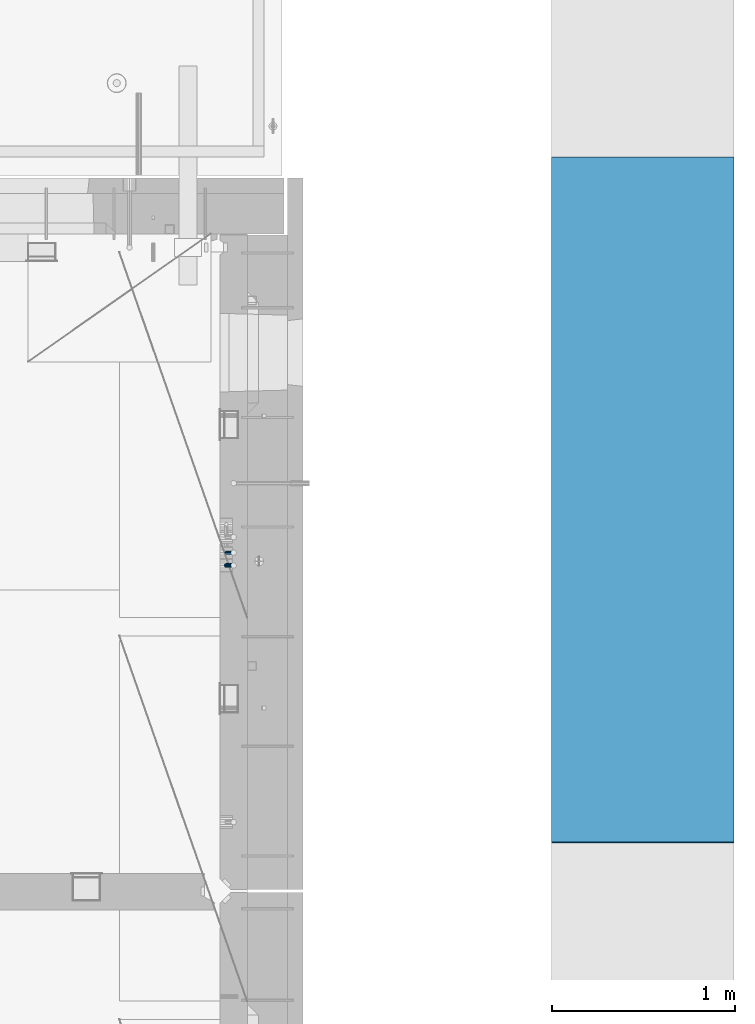
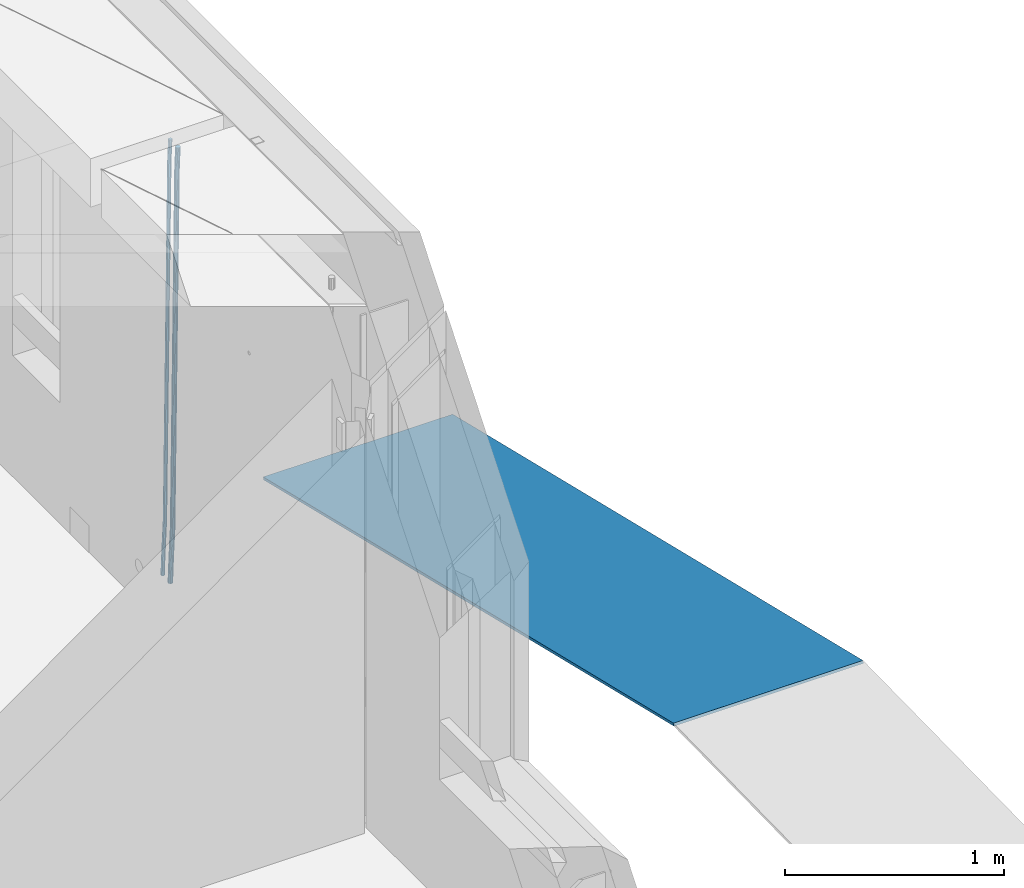
# One storey, part 116 of 325: 3 beams, 2 elements without a shape of their own.
"""IFC2X3 building model written with IfcOpenShell, lengths in millimetres."""

from ifc_helpers import new_model, si_unit, frame, origin_with_axes, place, context, subcontext, project, spatial, faceted_brep, material, type_object, element, aggregate, save


model = new_model("IFC2X3")

# Units and contexts
model_context = context("Model", 3, precision=1e-05, world=origin_with_axes())
body_context = subcontext(model_context, "Body", "Model", "MODEL_VIEW")
ifc_project = project(units=[si_unit("LENGTHUNIT", "METRE", prefix="MILLI"), si_unit("AREAUNIT", "SQUARE_METRE"), si_unit("VOLUMEUNIT", "CUBIC_METRE"), si_unit("MASSUNIT", "GRAM", prefix="KILO"), si_unit("TIMEUNIT", "SECOND"), si_unit("PLANEANGLEUNIT", "RADIAN"), si_unit("SOLIDANGLEUNIT", "STERADIAN"), si_unit("THERMODYNAMICTEMPERATUREUNIT", "DEGREE_CELSIUS"), si_unit("LUMINOUSINTENSITYUNIT", "LUMEN")], contexts=[model_context])

# Site, building, storey
site_placement = place(None, origin_with_axes())
site = spatial("IfcSite", under=ifc_project, at=site_placement, CompositionType="ELEMENT")
building_placement = place(site_placement, origin_with_axes())
building = spatial("IfcBuilding", under=site, at=building_placement, CompositionType="ELEMENT")
storey_placement = place(building_placement, origin_with_axes())
storey = spatial("IfcBuildingStorey", under=building, at=storey_placement, Name="1", CompositionType="ELEMENT", Elevation=0.0)

# Assembly, beams
assembly_1_placement = place(storey_placement, origin_with_axes())
assembly_1 = element("IfcElementAssembly", 1, at=assembly_1_placement, inside=storey, AssemblyPlace="NOTDEFINED", PredefinedType="REINFORCEMENT_UNIT")
ifc_material_1 = material()
beam_type_1 = type_object("IfcBeamType", Name="D20", PredefinedType="NOTDEFINED")
beam_1_placement = place(assembly_1_placement, frame((34944.9999977209, 18835.0002441367, 81990.0), z_axis=(0.999642804629538, 0.000205762999925497, -0.0267249099901003), x_axis=(0.0267249109941254, -4.30000210532798e-08, 0.999642825779465)))
beam_1 = element("IfcBeam", 2, at=beam_1_placement, type_object=beam_type_1, material=ifc_material_1, Name="JM20", ObjectType="D20", context=body_context, shape_type="Brep", body=[
    faceted_brep([(0.0, -10.0, 0.0), (-4.19531716033816e-08, -7.07106781186667, -7.07106781187031), (60.4266690400545, -7.0710677960451, -7.07106780570757), (60.4266690441291, -9.99999998418934, 6.15546014159918e-09), (0.0, 0.0, -10.0), (60.426669036824, 1.58106558956206e-08, -9.99999999384454), (4.196772351861e-08, 7.07106781186303, -7.07106781186667), (60.4266690363438, 7.07106782768096, -7.07106780570757), (0.0, 10.0, 0.0), (60.4266690388904, 10.0000000158179, 6.15182216279209e-09), (4.196772351861e-08, 7.07106781185939, 7.07106781185939), (60.4266690429649, 7.07106782768096, 7.07106781802577), (0.0, 0.0, 10.0), (60.4266690461809, 1.58179318532348e-08, 10.0000000061555), (-4.19531716033816e-08, -7.07106781187031, 7.07106781185939), (60.4266690466611, -7.07106779605238, 7.07106781802213), (61.0378400410118, -7.07106779588503, -7.07106780564936), (60.991799419251, -9.99999998403655, 6.21366780251265e-09), (61.0569027789461, 1.5985278878361e-08, -9.99999999378269), (61.0378209396877, 7.07106782784831, -7.07106780564936), (60.9917724058905, 10.0000000159635, 6.21366780251265e-09), (60.9457317841297, 7.07106782781193, 7.0710678180767), (60.9266690461809, 1.59488990902901e-08, 10.0000000062028), (60.9457508854539, -7.07106779591413, 7.0710678180767), (61.6489592143771, -7.07106614513759, -7.06310863441468), (61.5568818710308, -9.9999984576425, 0.00735959856683621), (61.6870830769039, 1.71821739058942e-06, -9.99179257185824), (61.6489210170112, 7.07106947854481, -7.06310888312146), (61.556827851804, 10.0000015422847, 0.00735924683976918), (61.4647505084577, 7.07106922979438, 7.07782747982128), (61.4266266459163, 1.36643211590126e-06, 10.0065114172685), (61.464788705809, -7.07106639389531, 7.07782772852806), (176.543135720174, -7.07075579406956, -5.56673531796696), (176.451058376813, -9.99968810657447, 1.50373291501455), (176.581259582701, 0.000312069292704109, -8.49541925541052), (176.543097522794, 7.07137982961285, -5.56673556667374), (176.451004357587, 10.00031189336, 1.50373256329476), (176.35892701424, 7.07137958085514, 8.57420079627263), (176.320803151699, 0.000311717507429421, 11.5028847337162), (176.358965211621, -7.07075604281999, 8.57420104497578), (177.098753836006, -7.07075429323595, -5.55949898843028), (176.98362511232, -9.99968666800123, 1.510669025065), (177.146421932586, 0.000313595905026887, -8.48805862247536), (177.098706077581, 7.07138133041735, -5.55949936166144), (176.983557571715, 10.0003133318824, 1.51066849724157), (176.868428848029, 7.07138095712435, 8.58083651073321), (176.820760751449, 0.000313067976094317, 11.5093961447819), (176.868476606425, -7.07075466652896, 8.58083688396073), (177.654312950661, -7.07075204110879, -5.54863964998367), (177.516135294456, -9.99968450931192, 1.52107783331303), (177.711524267797, 0.000315886711177882, -8.47701274570863), (177.654255632195, 7.07138358250813, -5.54864021007961), (177.516054233929, 10.0003154905207, 1.5210770412159), (177.377876577739, 7.0713830223176, 8.59079452451624), (177.320665260588, 0.000315094497636892, 11.5191676202448), (177.377933896176, -7.07075260129932, 8.59079508461218), (299.436796249574, -7.07025836271714, -3.1681962331204), (299.298618593355, -9.99919083092027, 3.90152125031091), (299.494007566798, 0.000809565110102994, -6.09656932889993), (299.436738931283, 7.07187726089978, -3.16819679320906), (299.298537533061, 10.0008091689197, 3.90152045822106), (299.160359876842, 7.07187670072017, 10.9712379416487), (299.103148559603, 0.000808772889286047, 13.8996110374392), (299.160417195119, -7.07025892290039, 10.9712385017483), (299.98743051647, -7.07025613056248, -3.15743315966392), (299.971788958996, -9.99918809853989, 3.91467979818117), (299.993912075952, 0.000811591617093654, -6.08679785393178), (299.987423933868, 7.07187949325817, -3.1574327280432), (299.971753863239, 10.0008119014747, 3.91467990454839), (299.95611230444, 7.07187992653053, 10.9867922621015), (299.949630744944, 0.000812204350950196, 13.9161569563694), (299.956118887014, -7.07025569729012, 10.9867918304735), (300.538107039494, -7.07025785017686, -3.16575821840888), (300.644985195438, -9.99919020432935, 3.90450175465594), (300.493854948218, 0.000810030429420294, -6.09435592770024), (300.538151196495, 7.071877773491, -3.16575855385963), (300.645047642858, 10.0008097955724, 3.90450128024895), (300.751925798773, 7.07187744142357, 10.9747612533101), (300.796177890064, 0.000809560813650023, 13.9033589625978), (300.751881641787, -7.07025818224065, 10.9747615887682), (2293.36490490142, -7.07648090940347, -33.2930642912361), (2293.47178305736, -10.0054132635523, -26.2228043181785), (2293.32065281013, -0.00541302880083094, -36.2216620005347), (2293.36494905842, 7.06565471425711, -33.2930646266868), (2293.47184550477, 9.99458673634581, -26.2228047925819), (2293.57872366071, 7.06565438219332, -19.1525448195243), (2293.62297575199, -0.00541349841296324, -16.2239471102366), (2293.57867950371, -7.0764812414709, -19.1525444840736), (2294.0658245362, -7.07648309818615, -33.3036607065333), (2294.05312277409, -10.0054150789219, -26.2315929392535), (2294.10928714235, -0.00541549149056664, -36.2335844756526), (2294.15805078732, 7.06565223761572, -33.3050546393533), (2294.18355038921, 9.99458451388637, -26.2335642579346), (2294.17084862708, 7.06565253314329, -19.1614964906439), (2294.12738602093, -0.00541507354500936, -16.2315727215355), (2294.07862237596, -7.07648280265857, -19.1601025578348), (2294.76670261032, -7.08562269121467, -33.294332712383), (2294.63442802057, -10.0129954178956, -26.2238563411993), (2294.89787471293, -0.0156988342423574, -36.2230891548279), (2294.95110548967, 7.05531064255774, -33.2944998654275), (2294.89521307347, 9.98530428734011, -26.2240927312887), (2294.76293848372, 7.0579315606592, -19.1536163601049), (2294.63176638114, -0.0119922963167483, -16.2248599176673), (2294.57853560438, -7.08300177311321, -19.1534492070678), (2316.52657204497, -7.36937582653991, -33.0047303660212), (2316.39429745522, -10.2967485532172, -25.9342539948302), (2316.65774414754, -0.299451969567599, -35.9334868084661), (2316.7109749243, 6.7715575072325, -33.0048975190657), (2316.65508250811, 9.70155115201487, -25.9344903849269), (2316.52280791836, 6.7741784253376, -18.8640140137468), (2316.39163581574, -0.295745431634714, -15.9352575713092), (2316.33840503903, -7.36675490843481, -18.863846860706), (2317.16202064224, -7.37766220584308, -32.9962731735213), (2317.05438744847, -10.3053562613532, -25.9254688497131), (2317.23607125619, -0.306993473008333, -35.925789846493), (2317.23316144495, 6.76474808850253, -32.9979477328052), (2317.15499573652, 9.6950321815566, -25.9278370341635), (2317.04736254275, 6.7673381260538, -18.8570327103698), (2316.97331192881, -0.303330606784584, -15.9275160373909), (2316.97622174003, -7.37507216829545, -18.8553581510787), (2317.79752306276, -7.37578610372293, -32.9880110666527), (2317.71453320107, -10.3033876998124, -25.9168792378296), (2317.81444760226, -0.305295583297266, -35.918287695793), (2317.75539265381, 6.76628640723357, -32.9911928173897), (2317.65495180529, 9.69652304524061, -25.9213789128698), (2317.5719619436, 6.76892144914746, -18.8502470840467), (2317.55503740412, -0.301569071270933, -15.9199704549137), (2317.61409235255, -7.3731510618054, -18.847065333317), (2417.8183084176, -7.07752398473531, -31.6906369377139), (2417.73531855589, -10.0051255808248, -24.6195051088798), (2417.83523295709, -0.007033464313281, -34.6209135668432), (2417.77617800863, 7.06454852621755, -31.6938186884508), (2417.67573716014, 9.99478516423187, -24.6240047839383), (2417.59274729842, 7.06718356813872, -17.5528729551006), (2417.57582275895, -0.00330695228694822, -14.6225963259749), (2417.6348777074, -7.07488894281778, -17.5496912043673)], [[[0, 1, 2, 3]], [[1, 4, 5, 2]], [[4, 6, 7, 5]], [[6, 8, 9, 7]], [[8, 10, 11, 9]], [[10, 12, 13, 11]], [[12, 14, 15, 13]], [[14, 0, 3, 15]], [[14, 12, 10, 8, 6, 4, 1, 0]], [[3, 2, 16, 17]], [[2, 5, 18, 16]], [[5, 7, 19, 18]], [[7, 9, 20, 19]], [[9, 11, 21, 20]], [[11, 13, 22, 21]], [[13, 15, 23, 22]], [[15, 3, 17, 23]], [[17, 16, 24, 25]], [[16, 18, 26, 24]], [[18, 19, 27, 26]], [[19, 20, 28, 27]], [[20, 21, 29, 28]], [[21, 22, 30, 29]], [[22, 23, 31, 30]], [[23, 17, 25, 31]], [[25, 24, 32, 33]], [[24, 26, 34, 32]], [[26, 27, 35, 34]], [[27, 28, 36, 35]], [[28, 29, 37, 36]], [[29, 30, 38, 37]], [[30, 31, 39, 38]], [[31, 25, 33, 39]], [[33, 32, 40, 41]], [[32, 34, 42, 40]], [[34, 35, 43, 42]], [[35, 36, 44, 43]], [[36, 37, 45, 44]], [[37, 38, 46, 45]], [[38, 39, 47, 46]], [[39, 33, 41, 47]], [[41, 40, 48, 49]], [[40, 42, 50, 48]], [[42, 43, 51, 50]], [[43, 44, 52, 51]], [[44, 45, 53, 52]], [[45, 46, 54, 53]], [[46, 47, 55, 54]], [[47, 41, 49, 55]], [[49, 48, 56, 57]], [[48, 50, 58, 56]], [[50, 51, 59, 58]], [[51, 52, 60, 59]], [[52, 53, 61, 60]], [[53, 54, 62, 61]], [[54, 55, 63, 62]], [[55, 49, 57, 63]], [[57, 56, 64, 65]], [[56, 58, 66, 64]], [[58, 59, 67, 66]], [[59, 60, 68, 67]], [[60, 61, 69, 68]], [[61, 62, 70, 69]], [[62, 63, 71, 70]], [[63, 57, 65, 71]], [[65, 64, 72, 73]], [[64, 66, 74, 72]], [[66, 67, 75, 74]], [[67, 68, 76, 75]], [[68, 69, 77, 76]], [[69, 70, 78, 77]], [[70, 71, 79, 78]], [[71, 65, 73, 79]], [[73, 72, 80, 81]], [[72, 74, 82, 80]], [[74, 75, 83, 82]], [[75, 76, 84, 83]], [[76, 77, 85, 84]], [[77, 78, 86, 85]], [[78, 79, 87, 86]], [[79, 73, 81, 87]], [[81, 80, 88, 89]], [[80, 82, 90, 88]], [[82, 83, 91, 90]], [[83, 84, 92, 91]], [[84, 85, 93, 92]], [[85, 86, 94, 93]], [[86, 87, 95, 94]], [[87, 81, 89, 95]], [[89, 88, 96, 97]], [[88, 90, 98, 96]], [[90, 91, 99, 98]], [[91, 92, 100, 99]], [[92, 93, 101, 100]], [[93, 94, 102, 101]], [[94, 95, 103, 102]], [[95, 89, 97, 103]], [[97, 96, 104, 105]], [[96, 98, 106, 104]], [[98, 99, 107, 106]], [[99, 100, 108, 107]], [[100, 101, 109, 108]], [[101, 102, 110, 109]], [[102, 103, 111, 110]], [[103, 97, 105, 111]], [[105, 104, 112, 113]], [[104, 106, 114, 112]], [[106, 107, 115, 114]], [[107, 108, 116, 115]], [[108, 109, 117, 116]], [[109, 110, 118, 117]], [[110, 111, 119, 118]], [[111, 105, 113, 119]], [[113, 112, 120, 121]], [[112, 114, 122, 120]], [[114, 115, 123, 122]], [[115, 116, 124, 123]], [[116, 117, 125, 124]], [[117, 118, 126, 125]], [[118, 119, 127, 126]], [[119, 113, 121, 127]], [[121, 120, 128, 129]], [[120, 122, 130, 128]], [[122, 123, 131, 130]], [[123, 124, 132, 131]], [[124, 125, 133, 132]], [[125, 126, 134, 133]], [[126, 127, 135, 134]], [[127, 121, 129, 135]], [[130, 131, 132, 133, 134, 135, 129, 128]]]),
])
beam_type_2 = type_object("IfcBeamType", Name="D25", PredefinedType="NOTDEFINED")
beam_2_placement = place(assembly_1_placement, frame((34944.9999977209, 18765.0002441367, 81990.0), z_axis=(0.999642804629538, 0.000205762999925497, -0.0267249099901003), x_axis=(0.0267249109941254, -4.30000210532798e-08, 0.999642825779465)))
beam_2 = element("IfcBeam", 3, at=beam_2_placement, type_object=beam_type_2, material=ifc_material_1, Name="JM25", ObjectType="D25", context=body_context, shape_type="Brep", body=[
    faceted_brep([(-7.41420080885291e-08, -12.5, -3.63797880709171e-12), (-6.42030499875546e-08, -10.8253175473074, -6.25000000000364), (60.4103898235917, -10.8253175318459, -6.2499999938409), (60.4103898269532, -12.4999999845422, 6.16273609921336e-09), (-3.70782800018787e-08, -6.25000000000364, -10.8253175473074), (60.4103898202884, -6.24999998454587, -10.8253175411446), (-1.45519152283669e-11, -3.63797880709171e-12, -12.5), (60.4103898179019, 1.54577719513327e-08, -12.4999999938373), (3.70637280866504e-08, 6.25, -10.8253175473074), (60.410389817087, 6.25000001545777, -10.825317541141), (6.42030499875546e-08, 10.8253175473001, -6.25000000000364), (60.410389818062, 10.8253175627578, -6.24999999383726), (7.41420080885291e-08, 12.4999999999927, 0.0), (60.4103898205503, 12.5000000154541, 6.16273609921336e-09), (6.42176019027829e-08, 10.8253175473001, 6.24999999999636), (60.4103898238973, 10.8253175627651, 6.2500000061591), (3.70928319171071e-08, 6.24999999999636, 10.8253175473037), (60.4103898272151, 6.25000001546141, 10.8253175534664), (1.45519152283669e-11, -3.63797880709171e-12, 12.4999999999964), (60.4103898296162, 1.54541339725256e-08, 12.5000000061591), (-3.7049176171422e-08, -6.25000000000364, 10.8253175473001), (60.4103898304165, -6.24999998454587, 10.8253175534701), (-6.41884980723262e-08, -10.8253175473074, 6.25), (60.4103898294561, -10.8253175318459, 6.25000000616637), (61.0324985728803, -10.8253175316895, -6.24999999377542), (60.991802792938, -12.4999999843931, 6.22458173893392e-09), (61.0622854283865, -6.24999998437852, -10.8253175410755), (61.0731819955545, 1.5628756955266e-08, -12.4999999937718), (61.0622685480339, 6.25000001562512, -10.8253175410791), (61.032469335245, 10.8253175629216, -6.24999999377178), (60.9917690322181, 12.5000000156033, 6.22458173893392e-09), (60.9510732522613, 10.8253175629034, 6.25000000621731), (60.9212863967696, 6.25000001558874, 10.8253175535247), (60.9103898296162, 1.55814632307738e-08, 12.5000000062137), (60.9213032771368, -6.24999998441126, 10.8253175535174), (60.9511024898966, -10.8253175317113, 6.25000000621731), (61.6545545670233, -10.8253158516927, -6.24189838219536), (61.573166454793, -12.499998414296, 0.00757164385504439), (61.7141257553885, -6.24999822394238, -10.8168280205282), (61.7359179680789, 1.80548886419274e-06, -12.491368569139), (61.7140919992817, 6.25000177601396, -10.8168282403167), (61.6544960997562, 10.8253192428383, -6.2418987628771), (61.5730989426083, 12.5000015856094, 0.0075712042817031), (61.4917108303925, 10.8253190230062, 6.25704123032847), (61.4321396420273, 6.25000139525582, 10.8319708686649), (61.4103474293224, 1.36582457344048e-06, 12.5065114172721), (61.4321733981196, -6.24999860470052, 10.8319710884571), (61.4917692976451, -10.8253160715249, 6.25704161101385), (176.524302641745, -10.8250056210964, -4.74584321979273), (176.442914529529, -12.4996881836996, 1.50362680625403), (176.583873830095, -6.24968799334965, -9.3207728581292), (176.605666042786, 0.000312036081595579, -10.9953134067364), (176.583840074018, 6.25031200660669, -9.32077307791769), (176.524244174492, 10.8256294734347, -4.74584360047811), (176.44284701733, 12.5003118162058, 1.50362636668069), (176.361458905099, 10.8256292535989, 7.75309639272746), (176.301887716749, 6.25031162585219, 12.3280260310676), (176.280095504058, 0.000311596420942806, 14.0025665796711), (176.301921472827, -6.24968837410415, 12.3280262508561), (176.361517372367, -10.8250058409321, 7.75309677341284), (177.085397012124, -10.8250041057399, -4.73853556792164), (176.983633547483, -12.4996867233749, 1.51066909103247), (177.159881729676, -6.24968643771717, -9.31327097355097), (177.187129580227, 0.000313606451527448, -10.987740468332), (177.159839524218, 6.25031356221734, -9.31327130338468), (177.085323910098, 10.8256309887511, -4.73853613920801), (176.983549136537, 12.5003132764905, 1.51066843136869), (176.881785671867, 10.8256306588555, 7.7598730903228), (176.80730095433, 6.25031299082912, 12.3346084959521), (176.780053103794, 0.000312946667690994, 14.0090779907332), (176.807343159802, -6.2496870091054, 12.3346088257895), (176.881858773908, -10.8250044356355, 7.7598736616128), (177.646431799818, -10.8250018318176, -4.72756919822132), (177.524295146417, -12.4996845320202, 1.52123723245313), (177.735828462886, -6.24968410334986, -9.30201312475765), (177.768531371941, 0.00031596292683389, -10.9763759912421), (177.735777808921, 6.25031589654827, -9.30201361973741), (177.646344064575, 10.8256332626152, -4.72757005553649), (177.524193838486, 12.5003154677688, 1.52123624250817), (177.402057185071, 10.8256327675663, 7.77004267317898), (177.312660521988, 6.2503150390985, 12.3444865997226), (177.279957612933, 0.00031497282179771, 14.0188494661961), (177.312711175953, -6.24968496079964, 12.3444870946951), (177.402144920314, -10.8250023268702, 7.77004353049415), (299.377443161706, -10.8245084454466, -2.34813158632096), (299.255306508276, -12.4991911456491, 3.90067484435349), (299.466839824803, -6.24919071697514, -6.92257551286093), (299.499542733873, 0.0008093492979242, -8.59693837933446), (299.466789170867, 6.250809282923, -6.92257600783341), (299.377355426492, 10.8261266489935, -2.34813244364341), (299.255205200388, 12.5008088541435, 3.90067385440125), (299.133068546944, 10.826126153941, 10.1494802850757), (299.043671883861, 6.25080842546959, 14.7239242116229), (299.010968974762, 0.000808359200163977, 16.3982870780892), (299.043722537797, -6.24919157442127, 14.7239247065918), (299.133156282158, -10.8245089404954, 10.1494811423981), (299.98561436501, -10.8245059804758, -2.33624385599614), (299.97179243555, -12.4991882411778, 3.91467976726199), (299.995742293278, -6.24918857328521, -6.91223722345239), (299.999447243041, 0.000811375455668895, -8.58716690387519), (299.995736475976, 6.25081142679483, -6.91223684201032), (299.985604289133, 10.8261291142808, -2.33624319533556), (299.971750386685, 12.5008117588586, 3.91467993563856), (299.957928457196, 10.8261294971744, 10.1656035610831), (299.947800528913, 6.25081208998381, 14.7415969285394), (299.944095579151, 0.00081214124293183, 16.4165266089549), (299.947806346216, -6.24918791008895, 14.7415965471009), (299.957938533058, -10.8245055975785, 10.1656029004225), (300.593832239858, -10.8245078794353, -2.34543881707941), (300.688302931099, -12.4991904788549, 3.90384712594823), (300.524685350189, -6.24919022474205, -6.92023371784308), (300.499390115292, 0.000809814544481924, -8.59472497713432), (300.524724372954, 6.25080977519247, -6.92023401429469), (300.593899829313, 10.8261272150703, -2.34543933054374), (300.688380976673, 12.5008095210287, 3.90384653304136), (300.782851667915, 10.8261269216127, 10.1531324760799), (300.851998557599, 6.25080926691589, 14.7279273768363), (300.877293792495, 0.000809227632998955, 16.4024186361276), (300.851959534804, -6.24919073302226, 14.7279276732806), (300.782784078474, -10.8245081728965, 10.153132989537), (2293.32930409742, -10.8307295605009, -32.4713622331001), (2293.42377478865, -12.5054121599169, -26.2220762900724), (2293.26015720774, -6.2554119058077, -37.0461571338565), (2293.23486197284, -0.00541186651753378, -38.7206483931477), (2293.26019623051, 6.24458809413409, -37.0461574303008), (2293.32937168686, 10.8199055340046, -32.4713627465644), (2293.42385283421, 12.4945878399631, -26.2220768829684), (2293.51832352545, 10.8199052405434, -19.972790939948), (2293.58747041514, 6.24458758585388, -15.3979960391844), (2293.61276565003, -0.00541245343265473, -13.7235047798931), (2293.58743139236, -6.25541241408428, -15.3979957427327), (2293.51825593603, -10.8307298539585, -19.9727904264691), (2294.0420846676, -10.8307317859326, -32.4821379598216), (2294.03681932652, -12.5054140739521, -26.2313442200393), (2294.06778164886, -6.2554144273563, -37.0583666982457), (2294.10702478497, -0.00541458957013674, -38.7338336404937), (2294.14929890928, 6.24458531819619, -37.0595987724118), (2294.18327670435, 10.8199028679592, -32.4842719748667), (2294.1998538474, 12.4945854171456, -26.2338083683717), (2294.19458850632, 10.819903129126, -19.9830146285858), (2294.16889152506, 6.24458577054975, -15.4067858901581), (2294.12964838895, -0.0054140672327776, -13.7313189479173), (2294.08737426462, -6.2554139749991, -15.4055538159919), (2294.05339646956, -10.8307315247621, -19.9808806135297), (2294.75482297382, -10.84002603931, -32.4726521173216), (2294.64982751427, -12.513407826169, -26.2231856868602), (2294.87535820232, -6.26594539088183, -37.0476186524102), (2294.97913588268, -0.0167870967634371, -38.7222267036377), (2295.0383488692, 6.23299192477134, -37.0477663960555), (2295.03713108998, 10.8087684320271, -32.4729080168181), (2294.97580884799, 12.4844668051373, -26.2234811741473), (2294.87081338844, 10.8110850182784, -19.9740147436787), (2294.7502781599, 6.23700436985018, -15.3990482086047), (2294.64650047956, -0.0121539242718427, -13.7244401573698), (2294.58728749304, -6.26193294580662, -15.3989004649666), (2294.58850527227, -10.8377094530588, -19.9737588441894), (2316.44667268227, -11.1228921988077, -32.1839550346631), (2316.34167722271, -12.7962739856739, -25.9344886042054), (2316.56720791078, -6.54881155039038, -36.7589215697517), (2316.67098559113, -0.299653256264719, -38.4335296209792), (2316.73019857766, 5.95012576527006, -36.759069313397), (2316.72898079845, 10.5259022725259, -32.1842109341669), (2316.66765855643, 12.2016006456361, -25.9347840914961), (2316.56266309689, 10.5282188587698, -19.6853176610275), (2316.44212786836, 5.95413821035254, -15.1103511259389), (2316.33835018802, -0.295020083769487, -13.4357430747186), (2316.27913720149, -6.54479910530426, -15.1102033823008), (2316.28035498071, -11.1205756125637, -19.685061761531), (2317.13234804722, -11.1318335458927, -32.1748293731798), (2317.04181141085, -12.8054038787741, -25.9251705100723), (2317.2154741603, -6.5572650749491, -36.7502937866229), (2317.26891617525, -0.307450393454928, -38.4255717558117), (2317.27835434731, 5.94297770185585, -36.7517739018112), (2317.24125972588, 10.5192220504723, -32.1773930078925), (2317.16757178486, 12.1950816748285, -25.9281307404563), (2317.0770351485, 10.5215113419545, -19.6784718773561), (2316.99390903539, 5.94694287101083, -15.1030074639057), (2316.94046702047, -0.302871810494253, -13.4277294947169), (2316.9310288484, -6.55329990579412, -15.1015273487101), (2316.96812346982, -11.1295442544142, -19.6759082426288), (2317.81808136747, -11.1298054502913, -32.1659056455355), (2317.74200467508, -12.803315894289, -25.9160547315114), (2317.86379538118, -6.55536082026447, -36.7418676070083), (2317.8668976831, -0.305700748642266, -38.417815303761), (2317.82655701396, 5.94458339541234, -36.7446799039099), (2317.75358262347, 10.5207330230332, -32.1707766866384), (2317.66752794063, 12.1965725370646, -25.9216793252963), (2317.59145124823, 10.5230620930706, -19.6718284112721), (2317.54573723453, 5.94861746304377, -15.0958664497994), (2317.54263493262, -0.301042608574789, -13.4199187530394), (2317.58297560175, -6.55132675263303, -15.0930541529051), (2317.65594999224, -11.1274763802539, -19.6669573701693), (2417.81884292323, -10.831603083323, -30.8687911350135), (2417.74276623082, -12.505113527317, -24.618940220982), (2417.86455693691, -6.25715845329614, -35.4447530964935), (2417.86765923884, -0.00749838167394046, -37.1207007932499), (2417.82731856969, 6.24278576237703, -35.4475653933878), (2417.75434417921, 10.8189353900088, -30.8736621761236), (2417.66828949639, 12.494774904033, -24.6245648147851), (2417.59221280397, 10.8212644600353, -18.3747139007501), (2417.54649879028, 6.2468198300121, -13.79875193927), (2417.54339648837, -0.00284024161010166, -12.1228042425173), (2417.5837371575, -6.25312438566107, -13.795939642383), (2417.65671154798, -10.8292740132893, -18.3698428596399)], [[[0, 1, 2, 3]], [[1, 4, 5, 2]], [[4, 6, 7, 5]], [[6, 8, 9, 7]], [[8, 10, 11, 9]], [[10, 12, 13, 11]], [[12, 14, 15, 13]], [[14, 16, 17, 15]], [[16, 18, 19, 17]], [[18, 20, 21, 19]], [[20, 22, 23, 21]], [[22, 0, 3, 23]], [[22, 20, 18, 16, 14, 12, 10, 8, 6, 4, 1, 0]], [[3, 2, 24, 25]], [[2, 5, 26, 24]], [[5, 7, 27, 26]], [[7, 9, 28, 27]], [[9, 11, 29, 28]], [[11, 13, 30, 29]], [[13, 15, 31, 30]], [[15, 17, 32, 31]], [[17, 19, 33, 32]], [[19, 21, 34, 33]], [[21, 23, 35, 34]], [[23, 3, 25, 35]], [[25, 24, 36, 37]], [[24, 26, 38, 36]], [[26, 27, 39, 38]], [[27, 28, 40, 39]], [[28, 29, 41, 40]], [[29, 30, 42, 41]], [[30, 31, 43, 42]], [[31, 32, 44, 43]], [[32, 33, 45, 44]], [[33, 34, 46, 45]], [[34, 35, 47, 46]], [[35, 25, 37, 47]], [[37, 36, 48, 49]], [[36, 38, 50, 48]], [[38, 39, 51, 50]], [[39, 40, 52, 51]], [[40, 41, 53, 52]], [[41, 42, 54, 53]], [[42, 43, 55, 54]], [[43, 44, 56, 55]], [[44, 45, 57, 56]], [[45, 46, 58, 57]], [[46, 47, 59, 58]], [[47, 37, 49, 59]], [[49, 48, 60, 61]], [[48, 50, 62, 60]], [[50, 51, 63, 62]], [[51, 52, 64, 63]], [[52, 53, 65, 64]], [[53, 54, 66, 65]], [[54, 55, 67, 66]], [[55, 56, 68, 67]], [[56, 57, 69, 68]], [[57, 58, 70, 69]], [[58, 59, 71, 70]], [[59, 49, 61, 71]], [[61, 60, 72, 73]], [[60, 62, 74, 72]], [[62, 63, 75, 74]], [[63, 64, 76, 75]], [[64, 65, 77, 76]], [[65, 66, 78, 77]], [[66, 67, 79, 78]], [[67, 68, 80, 79]], [[68, 69, 81, 80]], [[69, 70, 82, 81]], [[70, 71, 83, 82]], [[71, 61, 73, 83]], [[73, 72, 84, 85]], [[72, 74, 86, 84]], [[74, 75, 87, 86]], [[75, 76, 88, 87]], [[76, 77, 89, 88]], [[77, 78, 90, 89]], [[78, 79, 91, 90]], [[79, 80, 92, 91]], [[80, 81, 93, 92]], [[81, 82, 94, 93]], [[82, 83, 95, 94]], [[83, 73, 85, 95]], [[85, 84, 96, 97]], [[84, 86, 98, 96]], [[86, 87, 99, 98]], [[87, 88, 100, 99]], [[88, 89, 101, 100]], [[89, 90, 102, 101]], [[90, 91, 103, 102]], [[91, 92, 104, 103]], [[92, 93, 105, 104]], [[93, 94, 106, 105]], [[94, 95, 107, 106]], [[95, 85, 97, 107]], [[97, 96, 108, 109]], [[96, 98, 110, 108]], [[98, 99, 111, 110]], [[99, 100, 112, 111]], [[100, 101, 113, 112]], [[101, 102, 114, 113]], [[102, 103, 115, 114]], [[103, 104, 116, 115]], [[104, 105, 117, 116]], [[105, 106, 118, 117]], [[106, 107, 119, 118]], [[107, 97, 109, 119]], [[109, 108, 120, 121]], [[108, 110, 122, 120]], [[110, 111, 123, 122]], [[111, 112, 124, 123]], [[112, 113, 125, 124]], [[113, 114, 126, 125]], [[114, 115, 127, 126]], [[115, 116, 128, 127]], [[116, 117, 129, 128]], [[117, 118, 130, 129]], [[118, 119, 131, 130]], [[119, 109, 121, 131]], [[121, 120, 132, 133]], [[120, 122, 134, 132]], [[122, 123, 135, 134]], [[123, 124, 136, 135]], [[124, 125, 137, 136]], [[125, 126, 138, 137]], [[126, 127, 139, 138]], [[127, 128, 140, 139]], [[128, 129, 141, 140]], [[129, 130, 142, 141]], [[130, 131, 143, 142]], [[131, 121, 133, 143]], [[133, 132, 144, 145]], [[132, 134, 146, 144]], [[134, 135, 147, 146]], [[135, 136, 148, 147]], [[136, 137, 149, 148]], [[137, 138, 150, 149]], [[138, 139, 151, 150]], [[139, 140, 152, 151]], [[140, 141, 153, 152]], [[141, 142, 154, 153]], [[142, 143, 155, 154]], [[143, 133, 145, 155]], [[145, 144, 156, 157]], [[144, 146, 158, 156]], [[146, 147, 159, 158]], [[147, 148, 160, 159]], [[148, 149, 161, 160]], [[149, 150, 162, 161]], [[150, 151, 163, 162]], [[151, 152, 164, 163]], [[152, 153, 165, 164]], [[153, 154, 166, 165]], [[154, 155, 167, 166]], [[155, 145, 157, 167]], [[157, 156, 168, 169]], [[156, 158, 170, 168]], [[158, 159, 171, 170]], [[159, 160, 172, 171]], [[160, 161, 173, 172]], [[161, 162, 174, 173]], [[162, 163, 175, 174]], [[163, 164, 176, 175]], [[164, 165, 177, 176]], [[165, 166, 178, 177]], [[166, 167, 179, 178]], [[167, 157, 169, 179]], [[169, 168, 180, 181]], [[168, 170, 182, 180]], [[170, 171, 183, 182]], [[171, 172, 184, 183]], [[172, 173, 185, 184]], [[173, 174, 186, 185]], [[174, 175, 187, 186]], [[175, 176, 188, 187]], [[176, 177, 189, 188]], [[177, 178, 190, 189]], [[178, 179, 191, 190]], [[179, 169, 181, 191]], [[181, 180, 192, 193]], [[180, 182, 194, 192]], [[182, 183, 195, 194]], [[183, 184, 196, 195]], [[184, 185, 197, 196]], [[185, 186, 198, 197]], [[186, 187, 199, 198]], [[187, 188, 200, 199]], [[188, 189, 201, 200]], [[189, 190, 202, 201]], [[190, 191, 203, 202]], [[191, 181, 193, 203]], [[194, 195, 196, 197, 198, 199, 200, 201, 202, 203, 193, 192]]]),
])
aggregate(assembly_1, [beam_1, beam_2])

# Assembly, beam
assembly_2_placement = place(storey_placement, origin_with_axes())
assembly_2 = element("IfcElementAssembly", 4, at=assembly_2_placement, inside=storey, Name="Steel Assembly", AssemblyPlace="NOTDEFINED", PredefinedType="NOTDEFINED")
ifc_material_2 = material()
beam_type_3 = type_object("IfcBeamType", PredefinedType="NOTDEFINED")
beam_3_placement = place(assembly_2_placement, frame((37224.9964796872, 20998.2499223102, 80592.7070952352), z_axis=(1.0, 0.0, 0.0), x_axis=(0.0, -0.972387302089444, 0.233372952021464)))
beam_3 = element("IfcBeam", 5, at=beam_3_placement, type_object=beam_type_3, material=ifc_material_2, context=body_context, shape_type="Brep", body=[
    faceted_brep([(0.0, 7.5, -500.0), (0.0, 7.5, 500.0), (3856.48803965474, 7.5, 500.0), (3856.48803965474, 7.5, -500.0), (0.0, -7.5, 500.0), (3856.48803965473, -7.5, 500.0), (0.0, -7.5, -500.0), (3856.48803965473, -7.5, -500.0)], [[[0, 1, 2, 3]], [[1, 4, 5, 2]], [[4, 6, 7, 5]], [[6, 0, 3, 7]], [[5, 7, 3, 2]], [[6, 4, 1, 0]]]),
])
aggregate(assembly_2, [beam_3])

save(model, "model.ifc")
